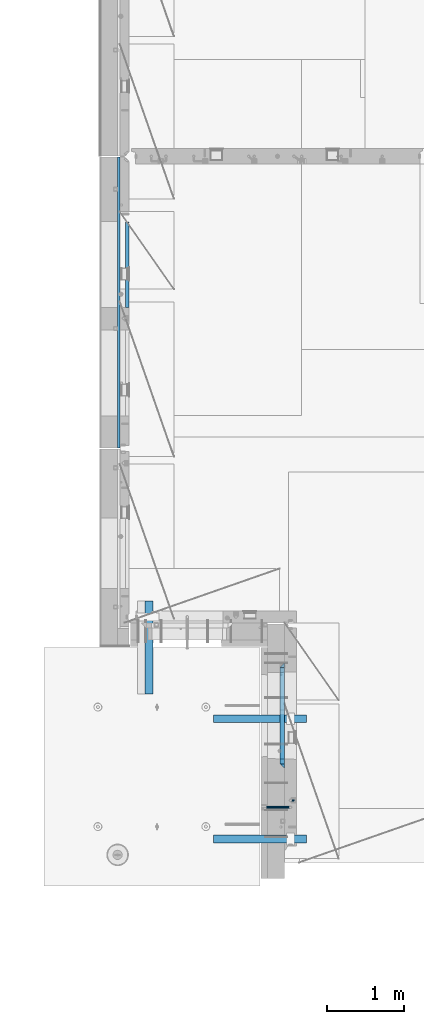
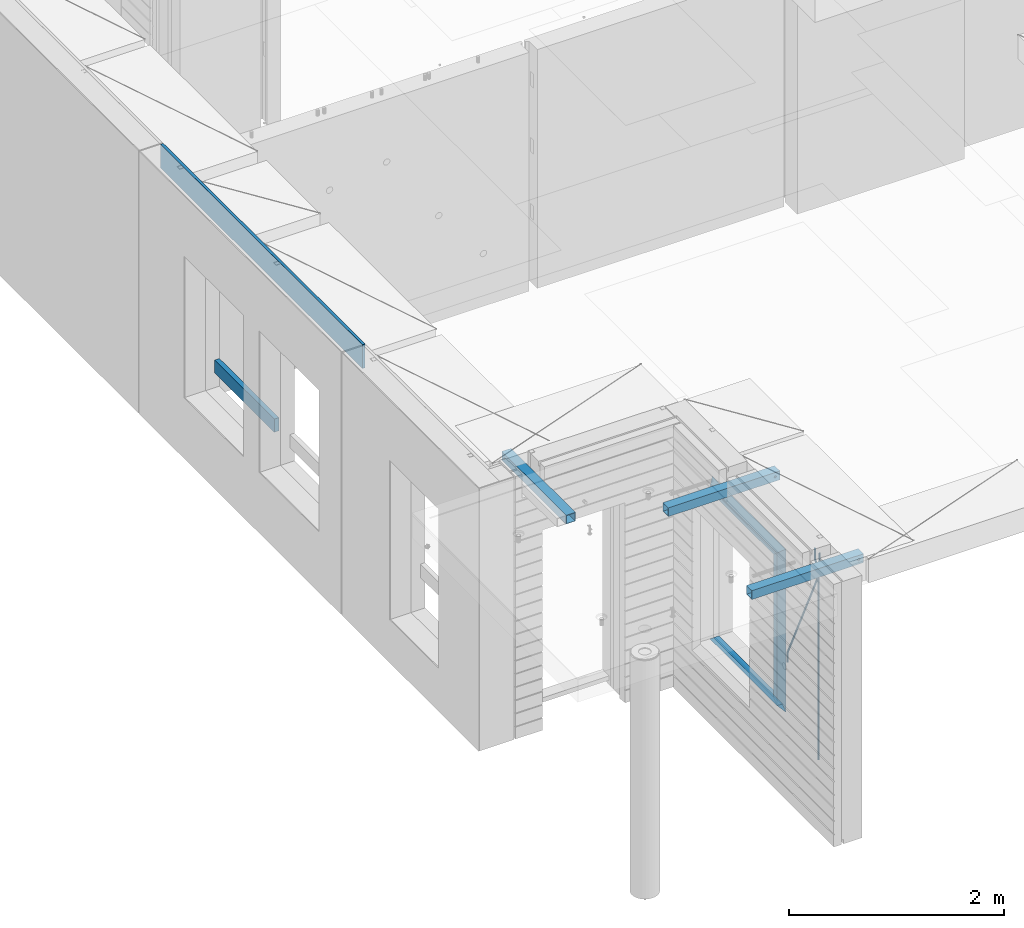
# One storey, part 77 of 309: 13 beams, 6 elements without a shape of their own.
"""IFC2X3 building model written with IfcOpenShell, lengths in millimetres."""

from ifc_helpers import new_model, si_unit, frame, origin_with_axes, place, context, subcontext, project, spatial, faceted_brep, material, type_object, element, aggregate, save


model = new_model("IFC2X3")

# Units and contexts
model_context = context("Model", 3, precision=1e-05, world=origin_with_axes())
body_context = subcontext(model_context, "Body", "Model", "MODEL_VIEW")
ifc_project = project(units=[si_unit("LENGTHUNIT", "METRE", prefix="MILLI"), si_unit("AREAUNIT", "SQUARE_METRE"), si_unit("VOLUMEUNIT", "CUBIC_METRE"), si_unit("MASSUNIT", "GRAM", prefix="KILO"), si_unit("TIMEUNIT", "SECOND"), si_unit("PLANEANGLEUNIT", "RADIAN"), si_unit("SOLIDANGLEUNIT", "STERADIAN"), si_unit("THERMODYNAMICTEMPERATUREUNIT", "DEGREE_CELSIUS"), si_unit("LUMINOUSINTENSITYUNIT", "LUMEN")], contexts=[model_context])

# Site, building, storey
site_placement = place(None, origin_with_axes())
site = spatial("IfcSite", under=ifc_project, at=site_placement, CompositionType="ELEMENT")
building_placement = place(site_placement, origin_with_axes())
building = spatial("IfcBuilding", under=site, at=building_placement, CompositionType="ELEMENT")
storey_placement = place(building_placement, origin_with_axes())
storey = spatial("IfcBuildingStorey", under=building, at=storey_placement, Name="7", CompositionType="ELEMENT", Elevation=0.0)

# Assembly, beams
assembly_1_placement = place(storey_placement, origin_with_axes())
assembly_1 = element("IfcElementAssembly", 1, at=assembly_1_placement, inside=storey, AssemblyPlace="NOTDEFINED", PredefinedType="REINFORCEMENT_UNIT")
ifc_material_1 = material()
beam_type_1 = type_object("IfcBeamType", Name="D20", PredefinedType="NOTDEFINED")
beam_1_placement = place(assembly_1_placement, frame((10084.9999999929, 8565.00000010149, 102407.5), z_axis=(-0.999999913638316, 0.000415599999849952, 0.0), x_axis=(0.0, 0.0, -1.0)))
beam_1 = element("IfcBeam", 2, at=beam_1_placement, type_object=beam_type_1, material=ifc_material_1, Name="JM20", ObjectType="D20", context=body_context, shape_type="Brep", body=[
    faceted_brep([(-0.00060564729210455, -9.99999998165731, 0.0), (-0.000428079845733009, -7.07106779890455, -7.07106781186667), (119.575515501536, -7.07830994756296, -7.07106481604933), (119.575337932896, -10.0072421307195, -3.43332612828817e-06), (0.0, 0.0, -10.0), (119.575943836026, -0.00724214867295814, -9.99999700418266), (0.00042843479604926, 7.07106779888636, -7.07106781186303), (119.57637202373, 7.06382565022977, -7.07106481604933), (0.00060564729210455, 9.99999998166459, 3.63797880709171e-12), (119.576549238118, 9.99275783300072, 2.99581552098971e-06), (0.000428079845733009, 7.07106779890819, 7.07106781186667), (119.576371669405, 7.06382565024978, 7.07107080768037), (0.0, 0.0, 10.0), (119.57594333493, -0.00724214864203532, 10.0000029958155), (-0.000428434810601175, -7.07106779888272, 7.07106781186667), (119.575515147211, -7.07830994754295, 7.07107080768037), (123.00654325854, -7.07836650239551, -6.96786008391246), (122.581588830741, -10.007295666459, 0.0904344953341933), (123.182419066041, -0.00729994480025198, -9.89151006310021), (123.006190977103, 7.06376911688858, -6.96788735351402), (122.581091016109, 9.99270432680532, 0.0903895128230943), (122.156136974867, 7.06377516229986, 7.14867767459873), (121.980261167351, -0.00729139528993983, 10.0723276537792), (122.156489256289, -7.07836045697513, 7.14870494419847), (237.077376207715, -7.07551629289992, -0.0988779924864502), (236.652422053201, -10.0044409119728, 6.95941204931296), (237.253252288647, -0.0044516184279928, -3.02253250974718), (237.077024472936, 7.06661932641327, -0.0989143382521434), (236.651924624995, 9.99555908263574, 6.95936064834314), (236.226970470365, 7.06663446442326, 14.0176506898479), (236.051094389448, -0.0044302100486675, 16.9413052071086), (236.227322205144, -7.07550115488812, 14.0176870356117), (256.715938387759, -7.07353516174771, 4.66794781703175), (253.858321224223, -10.0027051854922, 11.1357628166734), (257.898622435067, -0.00236892073007766, 1.98867362452802), (256.713573090979, 7.0686002544353, 4.66742272414376), (253.85497618909, 9.99729452004976, 11.1350202234971), (250.997359025234, 7.06812449537756, 17.6028352234607), (249.814674977912, -0.00304174564189452, 20.2821094159572), (250.999724322028, -7.07401092080545, 17.6033603163596), (1009.84102825288, -6.93521658215468, 337.477148757798), (1006.98341108896, -9.86438660663771, 343.944963757851), (1011.02371230032, 0.135949658781101, 334.7978745651), (1009.83866295629, 7.20691883402651, 337.476623664521), (1006.98006605446, 10.1356130998429, 343.944221163818), (1004.12244889054, 7.2064430753635, 350.412036163872), (1002.9397648431, 0.135276834424076, 353.091310356571), (1004.12481418712, -6.93569234081951, 350.412561257146), (1010.86335274603, -6.9350288225487, 337.928918327354), (1009.37086865908, -9.86394812736762, 344.999991477531), (1011.48104818776, 0.136033652863262, 334.999973251377), (1010.86211737194, 7.20710680115553, 337.928892551665), (1009.36912157628, 10.1360518725905, 344.9999550252), (1007.87663748935, 7.2071325677698, 352.071028175378), (1007.2589420476, 0.13607009235966, 354.999973251352), (1007.87787286344, -6.93500305593261, 352.071053951067), (1011.98104820926, -6.93502881915083, 337.92891832735), (1011.98104821818, -9.86394811943501, 344.999991477524), (1011.98104818776, 0.136033654382118, 334.999973251375), (1011.98104816627, 7.20710680455704, 337.928892551661), (1011.98104815738, 10.1360518805304, 344.999955025194), (1011.98104816629, 7.20713258024625, 352.071028175369), (1011.98104818778, 0.136070106711486, 354.999973251342), (1011.98104820927, -6.9350030434598, 352.071053951058), (1117.50000002154, -6.93502849844299, 337.928918327156), (1117.50000003044, -9.86394779872717, 344.999991477331), (1117.50000000004, 0.136033975091777, 334.999973251181), (1117.49999997855, 7.20710712526488, 337.928892551467), (1117.49999996964, 10.1360522012383, 344.999955025), (1117.49999997857, 7.20713290095409, 352.071028175174), (1117.50000000006, 0.136070427419327, 354.999973251148), (1117.50000002155, -6.93500272275196, 352.071053950864)], [[[0, 1, 2, 3]], [[1, 4, 5, 2]], [[4, 6, 7, 5]], [[6, 8, 9, 7]], [[8, 10, 11, 9]], [[10, 12, 13, 11]], [[12, 14, 15, 13]], [[14, 0, 3, 15]], [[14, 12, 10, 8, 6, 4, 1, 0]], [[3, 2, 16, 17]], [[2, 5, 18, 16]], [[5, 7, 19, 18]], [[7, 9, 20, 19]], [[9, 11, 21, 20]], [[11, 13, 22, 21]], [[13, 15, 23, 22]], [[15, 3, 17, 23]], [[17, 16, 24, 25]], [[16, 18, 26, 24]], [[18, 19, 27, 26]], [[19, 20, 28, 27]], [[20, 21, 29, 28]], [[21, 22, 30, 29]], [[22, 23, 31, 30]], [[23, 17, 25, 31]], [[25, 24, 32, 33]], [[24, 26, 34, 32]], [[26, 27, 35, 34]], [[27, 28, 36, 35]], [[28, 29, 37, 36]], [[29, 30, 38, 37]], [[30, 31, 39, 38]], [[31, 25, 33, 39]], [[33, 32, 40, 41]], [[32, 34, 42, 40]], [[34, 35, 43, 42]], [[35, 36, 44, 43]], [[36, 37, 45, 44]], [[37, 38, 46, 45]], [[38, 39, 47, 46]], [[39, 33, 41, 47]], [[41, 40, 48, 49]], [[40, 42, 50, 48]], [[42, 43, 51, 50]], [[43, 44, 52, 51]], [[44, 45, 53, 52]], [[45, 46, 54, 53]], [[46, 47, 55, 54]], [[47, 41, 49, 55]], [[49, 48, 56, 57]], [[48, 50, 58, 56]], [[50, 51, 59, 58]], [[51, 52, 60, 59]], [[52, 53, 61, 60]], [[53, 54, 62, 61]], [[54, 55, 63, 62]], [[55, 49, 57, 63]], [[57, 56, 64, 65]], [[56, 58, 66, 64]], [[58, 59, 67, 66]], [[59, 60, 68, 67]], [[60, 61, 69, 68]], [[61, 62, 70, 69]], [[62, 63, 71, 70]], [[63, 57, 65, 71]], [[66, 67, 68, 69, 70, 71, 65, 64]]]),
])
beam_2_placement = place(assembly_1_placement, frame((10085.0, 8655.00000000836, 102407.5), z_axis=(0.999999913638316, -0.000415599999849952, 0.0), x_axis=(0.0, 0.0, -1.0)))
beam_2 = element("IfcBeam", 3, at=beam_2_placement, type_object=beam_type_1, material=ifc_material_1, Name="JM20", ObjectType="D20", context=body_context, shape_type="Brep", body=[
    faceted_brep([(0.0, -10.0, 0.0), (-4.19531716033816e-08, -7.07106781186667, -7.07106781187031), (113.248091332178, -7.0710684840451, -7.0710678117357), (113.248091314759, -10.0000006713562, -2.51020537689328e-10), (0.0, 0.0, -10.0), (113.248091374131, -6.72178430249915e-07, -9.99999999986903), (4.196772351861e-08, 7.07106781186303, -7.07106781186667), (113.248091416113, 7.07106713968824, -7.07106781173934), (0.0, 10.0, 0.0), (113.248091433488, 9.99999932782521, 1.30967237055302e-10), (4.196772351861e-08, 7.07106781185939, 7.07106781185939), (113.248091416113, 7.0710671396846, 7.071067811994), (0.0, 0.0, 10.0), (113.248091374131, -6.72174792271107e-07, 10.0000000001273), (-4.19531716033816e-08, -7.07106781187031, 7.07106781185939), (113.248091332178, -7.0710684840451, 7.071067811994), (130.699843527167, -7.06993249763036, -4.33745683788584), (128.538066582521, -9.99900540317321, 2.39499413731755), (131.594536475241, 0.00119355250353692, -7.12624594330919), (130.698046432328, 7.07220300913468, -4.33773834422391), (128.535525107087, 10.0009944322555, 2.39459602660281), (126.373748162892, 7.07192152754578, 9.1270470011732), (125.479055214906, 0.000795477419160306, 11.9158361066184), (126.37554525779, -7.07021397921199, 9.12732850753673), (240.336258550378, -7.05529970173666, 30.8729495437874), (238.174481606227, -9.98437260450009, 37.6054005176375), (241.230951498423, 0.0158263482953771, 28.0841604381058), (240.334461455612, 7.0868358050102, 30.8726680369582), (238.171940130502, 10.0156272283348, 37.6050024077231), (236.010163186409, 7.08655432384694, 44.3374533824244), (235.115470238379, 0.0154282738185429, 47.1262424881097), (236.011960281176, -7.05558118289991, 44.3377348892536), (253.461915329972, -7.05444528127919, 32.9289287376414), (253.46191532613, -9.98337746617108, 39.9999965521893), (253.461915339081, 0.0166225284556276, 29.9999965443676), (253.461915348205, 7.08769034247234, 32.9289287273205), (253.461915352003, 10.0166225357716, 39.9999965370152), (253.461915348293, 7.08769035281148, 47.0710643509774), (253.461915339183, 0.0166225430875784, 49.999996544273), (253.46191533003, -7.05444527093641, 47.0710643613093), (2417.50000002384, -7.0544364694706, 32.9289287374122), (2417.5000000337, -9.98336865393321, 39.9999965507959), (2417.49999999997, 0.0166313408753922, 29.9999965456082), (2417.49999997609, 7.08769915426274, 32.9289287300708), (2417.4999999662, 10.0166313460668, 39.9999965404204), (2417.49999997608, 7.08769916160054, 47.0710643538114), (2417.49999999994, 0.0166313512581837, 49.9999965456154), (2417.50000002382, -7.05443646212916, 47.0710643611455)], [[[0, 1, 2, 3]], [[1, 4, 5, 2]], [[4, 6, 7, 5]], [[6, 8, 9, 7]], [[8, 10, 11, 9]], [[10, 12, 13, 11]], [[12, 14, 15, 13]], [[14, 0, 3, 15]], [[14, 12, 10, 8, 6, 4, 1, 0]], [[3, 2, 16, 17]], [[2, 5, 18, 16]], [[5, 7, 19, 18]], [[7, 9, 20, 19]], [[9, 11, 21, 20]], [[11, 13, 22, 21]], [[13, 15, 23, 22]], [[15, 3, 17, 23]], [[17, 16, 24, 25]], [[16, 18, 26, 24]], [[18, 19, 27, 26]], [[19, 20, 28, 27]], [[20, 21, 29, 28]], [[21, 22, 30, 29]], [[22, 23, 31, 30]], [[23, 17, 25, 31]], [[25, 24, 32, 33]], [[24, 26, 34, 32]], [[26, 27, 35, 34]], [[27, 28, 36, 35]], [[28, 29, 37, 36]], [[29, 30, 38, 37]], [[30, 31, 39, 38]], [[31, 25, 33, 39]], [[33, 32, 40, 41]], [[32, 34, 42, 40]], [[34, 35, 43, 42]], [[35, 36, 44, 43]], [[36, 37, 45, 44]], [[37, 38, 46, 45]], [[38, 39, 47, 46]], [[39, 33, 41, 47]], [[42, 43, 44, 45, 46, 47, 41, 40]]]),
])

# Assembly, beam
assembly_2_placement = place(storey_placement, origin_with_axes())
assembly_2 = element("IfcElementAssembly", 4, at=assembly_2_placement, inside=storey, AssemblyPlace="NOTDEFINED", PredefinedType="REINFORCEMENT_UNIT")
ifc_material_2 = material(Name="TIMBER/T24")
beam_type_2 = type_object("IfcBeamType", PredefinedType="NOTDEFINED")
beam_3_placement = place(assembly_2_placement, frame((7975.00000026382, 16134.5170325064, 100685.0), z_axis=(0.0, 0.0, 1.0), x_axis=(0.0, -1.0, 0.0)))
beam_3 = element("IfcBeam", 5, at=beam_3_placement, type_object=beam_type_2, material=ifc_material_2, context=body_context, shape_type="Brep", body=[
    faceted_brep([(-3.63797880709171e-12, 24.9999999999964, -75.0), (-3.63797880709171e-12, 24.9999999999964, 75.0), (1109.51662173163, 25.0, 75.0), (1109.51662173163, 25.0, -75.0), (0.0, -25.0000000000073, 75.0), (1109.51662173163, -25.0, 75.0), (0.0, -25.0000000000073, -75.0), (1109.51662173163, -25.0, -75.0)], [[[0, 1, 2, 3]], [[1, 4, 5, 2]], [[4, 6, 7, 5]], [[6, 0, 3, 7]], [[5, 7, 3, 2]], [[6, 4, 1, 0]]]),
])

# Assemblies, beams
assembly_3_placement = place(storey_placement, origin_with_axes())
assembly_3 = element("IfcElementAssembly", 6, at=assembly_3_placement, inside=storey, AssemblyPlace="NOTDEFINED", PredefinedType="REINFORCEMENT_UNIT")
assembly_4_placement = place(assembly_3_placement, origin_with_axes())
assembly_4 = element("IfcElementAssembly", 7, at=assembly_4_placement, AssemblyPlace="NOTDEFINED", PredefinedType="NOTDEFINED")
ifc_material_3 = material(Name="Undefined/350")
beam_type_3 = type_object("IfcBeamType", Name="100X100X5", PredefinedType="NOTDEFINED")
beam_4_placement = place(assembly_4_placement, frame((8254.95985679893, 10029.9865573969, 102555.0), z_axis=(0.0, 0.0, 1.0), x_axis=(2.22429999942101e-05, 0.999999999752625, 0.0)))
beam_4 = element("IfcBeam", 8, at=beam_4_placement, type_object=beam_type_3, material=ifc_material_3, ObjectType="100X100X5", context=body_context, shape_type="Brep", body=[
    faceted_brep([(1160.82642950046, -49.9743978761207, -6.25), (1160.82642783901, -44.9999999999991, -6.25), (1156.25111029171, -44.9999999999991, -10.8253175473074), (1156.25111195316, -49.9743994042774, -10.8253175473074), (1150.00111029171, -44.9999999999991, -12.5), (1150.00111195316, -49.9744014917787, -12.5), (1143.75111029171, -44.9999999999991, -10.8253175473074), (1143.75111195316, -49.9744035792783, -10.8253175473074), (1139.1757927444, -44.9999999999991, -6.25), (1139.17579440585, -49.9744051074349, -6.25), (1137.50111029171, -44.9999999999991, 0.0), (1137.50111195316, -49.9744056667778, 0.0), (1139.1757927444, -44.9999999999991, 6.25), (1139.17579440585, -49.9744051074349, 6.25), (1143.75111029171, -44.9999999999991, 10.8253175473074), (1143.75111195316, -49.9744035792783, 10.8253175473074), (1150.00111029171, -44.9999999999991, 12.5), (1150.00111195316, -49.9744014917787, 12.5), (1156.25111029171, -44.9999999999991, 10.8253175473074), (1156.25111195316, -49.9743994042774, 10.8253175473074), (1160.82642783901, -44.9999999999991, 6.25), (1160.82642950046, -49.9743978761207, 6.25), (1162.50111029171, -44.9999999999991, 0.0), (1162.50111195316, -49.9743973167779, 0.0), (1160.82639777901, 44.9999999999982, -6.25), (1160.82639610046, 50.0256021227788, -6.25), (1156.25107855315, 50.0256005946221, -10.8253175473074), (1156.2510802317, 44.9999999999982, -10.8253175473074), (1150.00107855316, 50.0255985071226, -12.5), (1150.00108023171, 44.9999999999982, -12.5), (1143.75107855316, 50.0255964196231, -10.8253175473074), (1143.75108023171, 44.9999999999982, -10.8253175473074), (1139.17576100585, 50.0255948914664, -6.25), (1139.1757626844, 44.9999999999982, -6.25), (1137.50107855316, 50.0255943321226, 0.0), (1137.5010802317, 44.9999999999982, 0.0), (1139.17576100585, 50.0255948914664, 6.25), (1139.1757626844, 44.9999999999982, 6.25), (1143.75107855316, 50.0255964196231, 10.8253175473074), (1143.75108023171, 44.9999999999982, 10.8253175473074), (1150.00107855316, 50.0255985071226, 12.5), (1150.00108023171, 44.9999999999982, 12.5), (1156.25107855315, 50.0256005946221, 10.8253175473074), (1156.2510802317, 44.9999999999982, 10.8253175473074), (1160.82639610046, 50.0256021227788, 6.25), (1160.82639777901, 44.9999999999982, 6.25), (1162.50107855316, 50.0256026821226, 0.0), (1162.50108023171, 44.9999999999982, 0.0), (1.81898940354586e-12, -50.0000000000009, -50.0), (1.81898940354586e-12, 49.9999999999991, -50.0), (1200.00449189278, 49.9999999999982, -50.0), (1200.00449189278, -50.0000000000009, -50.0), (1.81898940354586e-12, -50.0000000000009, 50.0), (1200.00449189278, -50.0000000000009, 50.0), (1.81898940354586e-12, 49.9999999999991, 50.0), (1200.00449189278, 49.9999999999982, 50.0), (0.0, 44.9999999999991, 45.0), (1.81898940354586e-12, -45.0000000000009, 45.0), (1.81898940354586e-12, -45.0000000000009, -45.0), (0.0, 44.9999999999991, -45.0), (1200.00449189278, 44.9999999999982, -45.0), (1200.00449189278, 44.9999999999982, 45.0), (1200.00449189278, -45.0000000000009, 45.0), (1200.00449189278, -45.0000000000009, -45.0)], [[[0, 1, 2, 3]], [[3, 2, 4, 5]], [[5, 4, 6, 7]], [[7, 6, 8, 9]], [[9, 8, 10, 11]], [[11, 10, 12, 13]], [[13, 12, 14, 15]], [[15, 14, 16, 17]], [[17, 16, 18, 19]], [[19, 18, 20, 21]], [[21, 20, 22, 23]], [[23, 22, 1, 0]], [[24, 25, 26, 27]], [[27, 26, 28, 29]], [[29, 28, 30, 31]], [[31, 30, 32, 33]], [[33, 32, 34, 35]], [[35, 34, 36, 37]], [[37, 36, 38, 39]], [[39, 38, 40, 41]], [[41, 40, 42, 43]], [[43, 42, 44, 45]], [[45, 44, 46, 47]], [[47, 46, 25, 24]], [[48, 49, 50, 51]], [[52, 48, 51, 53], [3, 5, 7, 9, 11, 13, 15, 17, 19, 21, 23, 0]], [[54, 52, 53, 55]], [[48, 52, 54, 49], [56, 57, 58, 59]], [[56, 59, 60, 61], [27, 29, 31, 33, 35, 37, 39, 41, 43, 45, 47, 24]], [[57, 56, 61, 62]], [[58, 57, 62, 63], [18, 16, 14, 12, 10, 8, 6, 4, 2, 1, 22, 20]], [[59, 58, 63, 60]], [[53, 51, 50, 55], [62, 61, 60, 63]], [[49, 54, 55, 50], [42, 40, 38, 36, 34, 32, 30, 28, 26, 25, 46, 44]]]),
])
aggregate(assembly_4, [beam_4])
assembly_5_placement = place(assembly_3_placement, origin_with_axes())
assembly_5 = element("IfcElementAssembly", 9, at=assembly_5_placement, AssemblyPlace="NOTDEFINED", PredefinedType="NOTDEFINED")
beam_5_placement = place(assembly_5_placement, frame((9089.99655739692, 9710.00014320107, 102555.0), z_axis=(0.0, 0.0, 1.0), x_axis=(0.999999999752625, -2.22429999942101e-05, 0.0)))
beam_5 = element("IfcBeam", 10, at=beam_5_placement, type_object=beam_type_3, material=ifc_material_3, ObjectType="100X100X5", context=body_context, shape_type="Brep", body=[
    faceted_brep([(1156.2510802317, 44.9999999999982, 10.8253175473074), (1156.25107855315, 50.0256005946221, 10.8253175473074), (1160.82639610046, 50.0256021227788, 6.25), (1160.82639777901, 44.9999999999982, 6.25), (1150.00108023171, 44.9999999999982, 12.5), (1150.00107855316, 50.0255985071226, 12.5), (1143.75108023171, 44.9999999999982, 10.8253175473074), (1143.75107855316, 50.0255964196231, 10.8253175473074), (1139.1757626844, 44.9999999999982, 6.25), (1139.17576100585, 50.0255948914664, 6.25), (1137.5010802317, 44.9999999999982, 0.0), (1137.50107855316, 50.0255943321226, 0.0), (1139.1757626844, 44.9999999999982, -6.25), (1139.17576100585, 50.0255948914664, -6.25), (1143.75108023171, 44.9999999999982, -10.8253175473074), (1143.75107855316, 50.0255964196231, -10.8253175473074), (1150.00108023171, 44.9999999999982, -12.5), (1150.00107855316, 50.0255985071226, -12.5), (1156.2510802317, 44.9999999999982, -10.8253175473074), (1156.25107855315, 50.0256005946221, -10.8253175473074), (1160.82639777901, 44.9999999999982, -6.25), (1160.82639610046, 50.0256021227788, -6.25), (1162.50108023171, 44.9999999999982, 0.0), (1162.50107855316, 50.0256026821226, 0.0), (1156.25111195316, -49.9743994042774, 10.8253175473074), (1156.25111029171, -44.9999999999991, 10.8253175473074), (1160.82642783901, -44.9999999999991, 6.25), (1160.82642950046, -49.9743978761207, 6.25), (1150.00111195316, -49.9744014917787, 12.5), (1150.00111029171, -44.9999999999991, 12.5), (1143.75111195316, -49.9744035792783, 10.8253175473074), (1143.75111029171, -44.9999999999991, 10.8253175473074), (1139.17579440585, -49.9744051074349, 6.25), (1139.1757927444, -44.9999999999991, 6.25), (1137.50111195316, -49.9744056667778, 0.0), (1137.50111029171, -44.9999999999991, 0.0), (1139.17579440585, -49.9744051074349, -6.25), (1139.1757927444, -44.9999999999991, -6.25), (1143.75111195316, -49.9744035792783, -10.8253175473074), (1143.75111029171, -44.9999999999991, -10.8253175473074), (1150.00111195316, -49.9744014917787, -12.5), (1150.00111029171, -44.9999999999991, -12.5), (1156.25111195316, -49.9743994042774, -10.8253175473074), (1156.25111029171, -44.9999999999991, -10.8253175473074), (1160.82642950046, -49.9743978761207, -6.25), (1160.82642783901, -44.9999999999991, -6.25), (1162.50111195316, -49.9743973167779, 0.0), (1162.50111029171, -44.9999999999991, 0.0), (1.81898940354586e-12, -50.0000000000009, -50.0), (1.81898940354586e-12, 49.9999999999991, -50.0), (1200.00449189278, 49.9999999999982, -50.0), (1200.00449189278, -50.0000000000009, -50.0), (1.81898940354586e-12, 49.9999999999991, 50.0), (1.81898940354586e-12, -50.0000000000009, 50.0), (1200.00449189278, -50.0000000000009, 50.0), (1200.00449189278, 49.9999999999982, 50.0), (0.0, 44.9999999999991, 45.0), (1.81898940354586e-12, -45.0000000000009, 45.0), (1.81898940354586e-12, -45.0000000000009, -45.0), (0.0, 44.9999999999991, -45.0), (1200.00449189278, 44.9999999999982, -45.0), (1200.00449189278, 44.9999999999982, 45.0), (1200.00449189278, -45.0000000000009, 45.0), (1200.00449189278, -45.0000000000009, -45.0)], [[[0, 1, 2, 3]], [[4, 5, 1, 0]], [[6, 7, 5, 4]], [[8, 9, 7, 6]], [[10, 11, 9, 8]], [[12, 13, 11, 10]], [[14, 15, 13, 12]], [[16, 17, 15, 14]], [[18, 19, 17, 16]], [[20, 21, 19, 18]], [[22, 23, 21, 20]], [[3, 2, 23, 22]], [[24, 25, 26, 27]], [[28, 29, 25, 24]], [[30, 31, 29, 28]], [[32, 33, 31, 30]], [[34, 35, 33, 32]], [[36, 37, 35, 34]], [[38, 39, 37, 36]], [[40, 41, 39, 38]], [[42, 43, 41, 40]], [[44, 45, 43, 42]], [[46, 47, 45, 44]], [[27, 26, 47, 46]], [[48, 49, 50, 51]], [[52, 53, 54, 55]], [[49, 52, 55, 50], [1, 5, 7, 9, 11, 13, 15, 17, 19, 21, 23, 2]], [[48, 53, 52, 49], [56, 57, 58, 59]], [[56, 59, 60, 61], [18, 16, 14, 12, 10, 8, 6, 4, 0, 3, 22, 20]], [[57, 56, 61, 62]], [[58, 57, 62, 63], [25, 29, 31, 33, 35, 37, 39, 41, 43, 45, 47, 26]], [[59, 58, 63, 60]], [[54, 51, 50, 55], [62, 61, 60, 63]], [[53, 48, 51, 54], [42, 40, 38, 36, 34, 32, 30, 28, 24, 27, 46, 44]]]),
])
aggregate(assembly_5, [beam_5])
assembly_6_placement = place(assembly_3_placement, origin_with_axes())
assembly_6 = element("IfcElementAssembly", 11, at=assembly_6_placement, AssemblyPlace="NOTDEFINED", PredefinedType="NOTDEFINED")
aggregate(assembly_3, [assembly_4, assembly_5, assembly_6])
beam_6_placement = place(assembly_6_placement, frame((9089.99655739692, 8155.00014320107, 102555.0), z_axis=(0.0, 0.0, 1.0), x_axis=(0.999999999752625, -2.22429999942101e-05, 0.0)))
beam_6 = element("IfcBeam", 12, at=beam_6_placement, type_object=beam_type_3, material=ifc_material_3, ObjectType="100X100X5", context=body_context, shape_type="Brep", body=[
    faceted_brep([(1156.2510802317, 44.9999999999982, 10.8253175473074), (1156.25107855315, 50.0256005946221, 10.8253175473074), (1160.82639610046, 50.0256021227788, 6.25), (1160.82639777901, 44.9999999999982, 6.25), (1150.00108023171, 44.9999999999982, 12.5), (1150.00107855316, 50.0255985071226, 12.5), (1143.75108023171, 44.9999999999982, 10.8253175473074), (1143.75107855316, 50.0255964196231, 10.8253175473074), (1139.1757626844, 44.9999999999982, 6.25), (1139.17576100585, 50.0255948914664, 6.25), (1137.5010802317, 44.9999999999982, 0.0), (1137.50107855316, 50.0255943321226, 0.0), (1139.1757626844, 44.9999999999982, -6.25), (1139.17576100585, 50.0255948914664, -6.25), (1143.75108023171, 44.9999999999982, -10.8253175473074), (1143.75107855316, 50.0255964196231, -10.8253175473074), (1150.00108023171, 44.9999999999982, -12.5), (1150.00107855316, 50.0255985071226, -12.5), (1156.2510802317, 44.9999999999982, -10.8253175473074), (1156.25107855315, 50.0256005946221, -10.8253175473074), (1160.82639777901, 44.9999999999982, -6.25), (1160.82639610046, 50.0256021227788, -6.25), (1162.50108023171, 44.9999999999982, 0.0), (1162.50107855316, 50.0256026821226, 0.0), (1156.25111195316, -49.9743994042774, 10.8253175473074), (1156.25111029171, -44.9999999999991, 10.8253175473074), (1160.82642783901, -44.9999999999991, 6.25), (1160.82642950046, -49.9743978761207, 6.25), (1150.00111195316, -49.9744014917787, 12.5), (1150.00111029171, -44.9999999999991, 12.5), (1143.75111195316, -49.9744035792783, 10.8253175473074), (1143.75111029171, -44.9999999999991, 10.8253175473074), (1139.17579440585, -49.9744051074349, 6.25), (1139.1757927444, -44.9999999999991, 6.25), (1137.50111195316, -49.9744056667778, 0.0), (1137.50111029171, -44.9999999999991, 0.0), (1139.17579440585, -49.9744051074349, -6.25), (1139.1757927444, -44.9999999999991, -6.25), (1143.75111195316, -49.9744035792783, -10.8253175473074), (1143.75111029171, -44.9999999999991, -10.8253175473074), (1150.00111195316, -49.9744014917787, -12.5), (1150.00111029171, -44.9999999999991, -12.5), (1156.25111195316, -49.9743994042774, -10.8253175473074), (1156.25111029171, -44.9999999999991, -10.8253175473074), (1160.82642950046, -49.9743978761207, -6.25), (1160.82642783901, -44.9999999999991, -6.25), (1162.50111195316, -49.9743973167779, 0.0), (1162.50111029171, -44.9999999999991, 0.0), (1.81898940354586e-12, -50.0000000000009, -50.0), (1.81898940354586e-12, 49.9999999999991, -50.0), (1200.00449189278, 49.9999999999982, -50.0), (1200.00449189278, -50.0000000000009, -50.0), (1.81898940354586e-12, 49.9999999999991, 50.0), (1.81898940354586e-12, -50.0000000000009, 50.0), (1200.00449189278, -50.0000000000009, 50.0), (1200.00449189278, 49.9999999999982, 50.0), (0.0, 44.9999999999991, 45.0), (1.81898940354586e-12, -45.0000000000009, 45.0), (1.81898940354586e-12, -45.0000000000009, -45.0), (0.0, 44.9999999999991, -45.0), (1200.00449189278, 44.9999999999982, -45.0), (1200.00449189278, 44.9999999999982, 45.0), (1200.00449189278, -45.0000000000009, 45.0), (1200.00449189278, -45.0000000000009, -45.0)], [[[0, 1, 2, 3]], [[4, 5, 1, 0]], [[6, 7, 5, 4]], [[8, 9, 7, 6]], [[10, 11, 9, 8]], [[12, 13, 11, 10]], [[14, 15, 13, 12]], [[16, 17, 15, 14]], [[18, 19, 17, 16]], [[20, 21, 19, 18]], [[22, 23, 21, 20]], [[3, 2, 23, 22]], [[24, 25, 26, 27]], [[28, 29, 25, 24]], [[30, 31, 29, 28]], [[32, 33, 31, 30]], [[34, 35, 33, 32]], [[36, 37, 35, 34]], [[38, 39, 37, 36]], [[40, 41, 39, 38]], [[42, 43, 41, 40]], [[44, 45, 43, 42]], [[46, 47, 45, 44]], [[27, 26, 47, 46]], [[48, 49, 50, 51]], [[52, 53, 54, 55]], [[49, 52, 55, 50], [1, 5, 7, 9, 11, 13, 15, 17, 19, 21, 23, 2]], [[48, 53, 52, 49], [56, 57, 58, 59]], [[56, 59, 60, 61], [18, 16, 14, 12, 10, 8, 6, 4, 0, 3, 22, 20]], [[57, 56, 61, 62]], [[58, 57, 62, 63], [25, 29, 31, 33, 35, 37, 39, 41, 43, 45, 47, 26]], [[59, 58, 63, 60]], [[54, 51, 50, 55], [62, 61, 60, 63]], [[53, 48, 51, 54], [42, 40, 38, 36, 34, 32, 30, 28, 24, 27, 46, 44]]]),
])
aggregate(assembly_6, [beam_6])

# Beam
ifc_material_4 = material(Name="CONCRETE/C25/30")
beam_type_4 = type_object("IfcBeamType", PredefinedType="NOTDEFINED")
beam_7_placement = place(assembly_1_placement, frame((9980.0, 10435.001591409, 102145.0), z_axis=(0.0, 0.0, -1.0), x_axis=(0.0, -1.0, 0.0)))
beam_7 = element("IfcBeam", 13, at=beam_7_placement, type_object=beam_type_4, material=ifc_material_4, Name="SK", context=body_context, shape_type="Brep", body=[
    faceted_brep([(60.0000000000073, 30.0, 30.0), (0.0, -30.0, -30.0), (60.0000000000073, -30.0, 30.0), (1309.99847412109, -30.0, 30.0), (1309.99847412109, 30.0, 30.0), (1369.99847412109, -30.0, -30.0)], [[[0, 1, 2]], [[0, 2, 3, 4]], [[1, 0, 4, 5]], [[2, 1, 5, 3]], [[4, 3, 5]]]),
])

beam_8_placement = place(assembly_1_placement, frame((9980.00000000155, 10375.001591409, 102085.0), z_axis=(0.0, 0.0, -1.0), x_axis=(0.0, -1.0, 0.0)))
beam_8 = element("IfcBeam", 14, at=beam_8_placement, type_object=beam_type_4, material=ifc_material_4, Name="SK", context=body_context, shape_type="Brep", body=[
    faceted_brep([(65.6741497967687, 29.999999998452, 26.2921283848846), (0.0, 30.0, -30.0), (0.0, -30.0, -30.0), (64.0525281752307, -29.999999998452, 24.9021669953072), (64.0525281752307, -29.999999998452, 24.0540540541406), (65.6741497967687, 29.999999998452, 25.6756756756804), (1185.94442006696, -29.999999998452, 24.0540540541406), (1184.32279844542, 29.999999998452, 25.6756756756804), (1185.94442006696, -29.999999998452, 24.9034748915001), (1184.32279844542, 29.999999998452, 26.2934362810629), (1249.99847412109, 29.999999998452, -30.0), (1249.99847412109, -29.999999998452, -30.0)], [[[0, 1, 2, 3]], [[4, 5, 0, 3]], [[6, 7, 5, 4]], [[7, 6, 8, 9]], [[1, 0, 5, 7, 9, 10]], [[2, 1, 10, 11]], [[6, 4, 3, 2, 11, 8]], [[10, 9, 8, 11]]]),
])

beam_9_placement = place(assembly_1_placement, frame((9980.0, 9095.00311728789, 102175.0), z_axis=(0.0, 1.0, 0.0), x_axis=(0.0, 0.0, -1.0)))
beam_9 = element("IfcBeam", 15, at=beam_9_placement, type_object=beam_type_4, material=ifc_material_4, Name="SK", context=body_context, shape_type="Brep", body=[
    faceted_brep([(60.0000000000073, 30.0, 30.0), (0.0, -30.0, -30.0), (60.0000000000073, -30.0, 30.0), (1795.00000000001, -30.0, 30.0), (1795.00000000001, 30.0, 30.0), (1855.0, -30.0, -30.0)], [[[0, 1, 2]], [[3, 4, 0, 2]], [[4, 5, 1, 0]], [[5, 3, 2, 1]], [[3, 5, 4]]]),
])

beam_10_placement = place(assembly_1_placement, frame((9980.0, 9065.00311728789, 100350.0), z_axis=(0.0, 0.0, 1.0), x_axis=(0.0, 1.0, 0.0)))
beam_10 = element("IfcBeam", 16, at=beam_10_placement, type_object=beam_type_4, material=ifc_material_4, Name="SK", context=body_context, shape_type="Brep", body=[
    faceted_brep([(1309.99847412109, 30.0, 30.0), (1309.99847412109, -30.0, 30.0), (1369.99847412109, -30.0, -30.0), (60.0000000000073, -30.0, 30.0), (0.0, -30.0, -30.0), (60.0000000000073, 30.0, 30.0)], [[[0, 1, 2]], [[3, 4, 2, 1]], [[4, 5, 0, 2]], [[5, 3, 1, 0]], [[5, 4, 3]]]),
])

beam_11_placement = place(assembly_1_placement, frame((9980.00000000155, 9125.00311728789, 100410.0), z_axis=(0.0, 0.0, 1.0), x_axis=(0.0, 1.0, 0.0)))
beam_11 = element("IfcBeam", 17, at=beam_11_placement, type_object=beam_type_4, material=ifc_material_4, Name="SK", context=body_context, shape_type="Brep", body=[
    faceted_brep([(1184.32432432433, 29.999999998452, 26.2921283848846), (1185.94594594586, -29.999999998452, 24.9021669952926), (1249.99847412109, -29.999999998452, -30.0), (1249.99847412109, 29.999999998452, -30.0), (1184.32432432432, 29.9999988381387, 25.6756756756804), (1185.94594588314, -29.9999988381387, 24.0540541168593), (65.6756756756768, 30.0, 25.6756756756804), (64.0540540540533, -30.0, 24.0540540540533), (64.0540540540533, -30.0, 24.9034748914419), (0.0, -30.0, -30.0), (0.0, 30.0, -30.0), (65.6756756756768, 30.0, 26.293436281092)], [[[0, 1, 2, 3]], [[4, 5, 1, 0]], [[5, 4, 6, 7]], [[2, 1, 5, 7, 8, 9]], [[9, 10, 3, 2]], [[6, 4, 0, 3, 10, 11]], [[7, 6, 11, 8]], [[9, 8, 11, 10]]]),
])

beam_type_5 = type_object("IfcBeamType", PredefinedType="NOTDEFINED")
beam_12_placement = place(assembly_1_placement, frame((9980.00000000155, 9160.00311728789, 102115.0), z_axis=(0.0, 1.0, 0.0), x_axis=(0.0, 0.0, -1.0)))
beam_12 = element("IfcBeam", 18, at=beam_12_placement, type_object=beam_type_5, material=ifc_material_4, Name="SK", context=body_context, shape_type="Brep", body=[
    faceted_brep([(0.0, -30.0, -35.0), (54.9034748914273, -30.0, 29.0540540540533), (56.2934362811066, 30.0, 30.6756756756768), (0.0, 30.0, -35.0), (1680.09652510857, -30.0, 29.0540540540533), (1678.70656371891, 30.0, 30.6756756756768), (1735.0, 30.0, -35.0), (1735.0, -30.0, -35.0)], [[[0, 1, 2, 3]], [[2, 1, 4, 5]], [[3, 2, 5, 6]], [[6, 7, 0, 3]], [[1, 0, 7, 4]], [[7, 6, 5, 4]]]),
])

aggregate(assembly_1, [beam_1, beam_2, beam_7, beam_8, beam_9, beam_12, beam_10, beam_11])

beam_type_6 = type_object("IfcBeamType", Name="270X30", PredefinedType="NOTDEFINED")
beam_13_placement = place(assembly_2_placement, frame((7865.00000036742, 16969.9999989039, 102605.0), z_axis=(0.0, 0.0, 1.0), x_axis=(0.0, -1.0, 0.0)))
beam_13 = element("IfcBeam", 19, at=beam_13_placement, type_object=beam_type_6, material=ifc_material_4, ObjectType="270X30", context=body_context, shape_type="Brep", body=[
    faceted_brep([(0.0, 15.0, -135.0), (0.0, 15.0, 135.0), (3759.99957708467, 15.0, 135.0), (3759.99957708467, 15.0, -135.0), (0.0, -15.0, 135.0), (3759.99957708467, -15.0, 135.0), (0.0, -15.0, -135.0), (3759.99957708467, -15.0, -135.0)], [[[0, 1, 2, 3]], [[1, 4, 5, 2]], [[4, 6, 7, 5]], [[6, 0, 3, 7]], [[5, 7, 3, 2]], [[6, 4, 1, 0]]]),
])

aggregate(assembly_2, [beam_13, beam_3])

save(model, "model.ifc")
